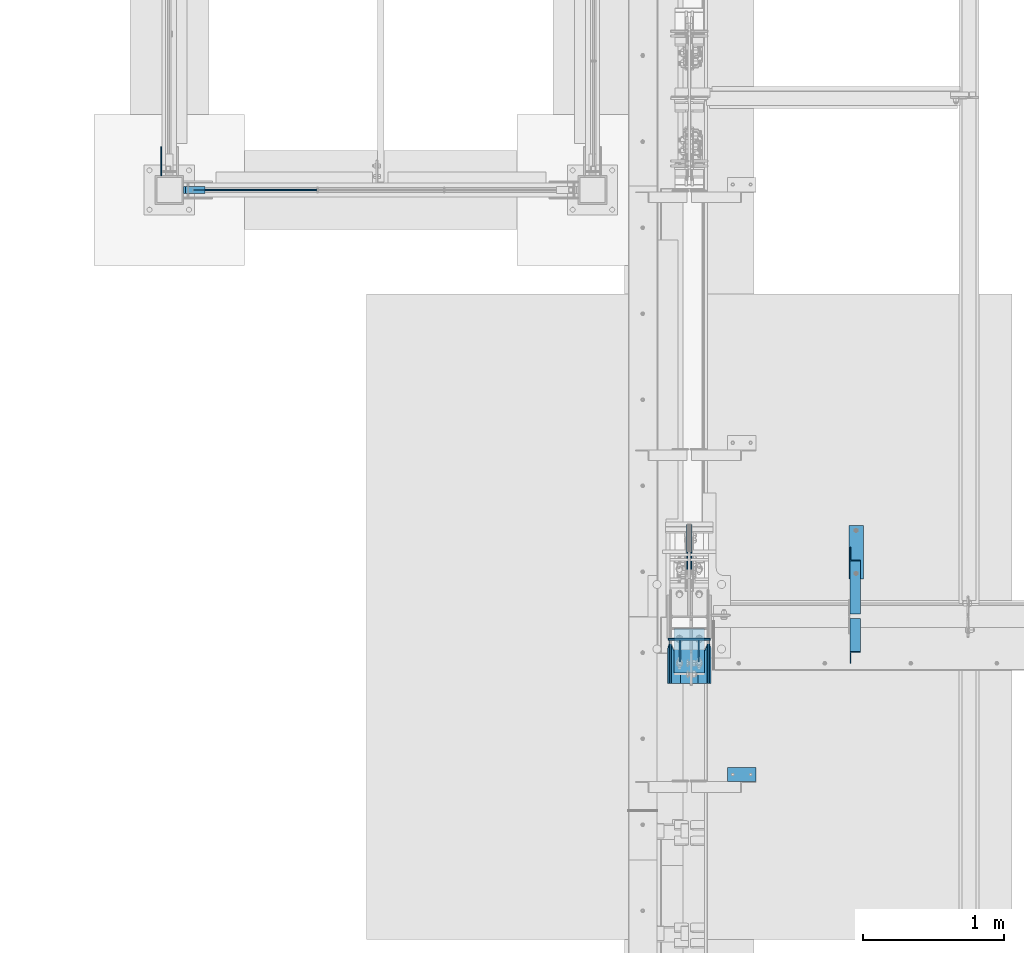
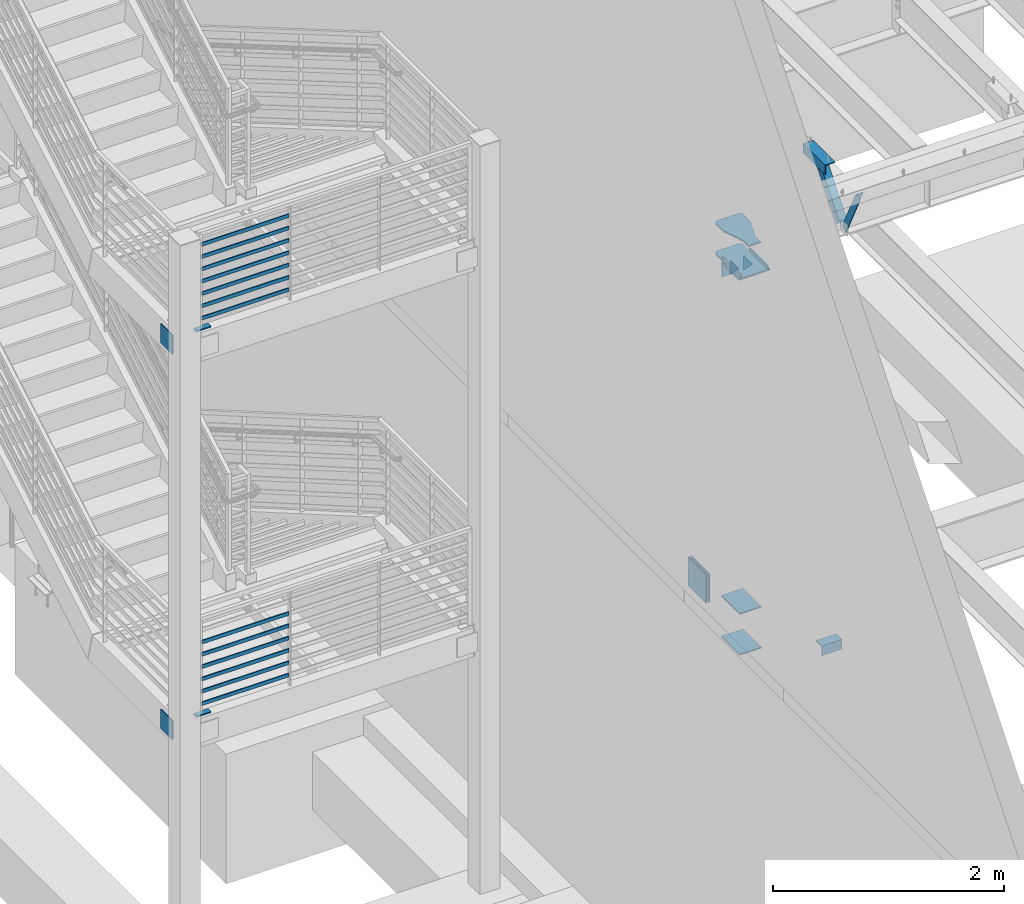
# One storey, part 830 of 1179: 30 beams, 2 members, 13 elements without a shape of their own.
"""IFC2X3 building model written with IfcOpenShell, lengths in millimetres."""

import ifcopenshell
import ifcopenshell.guid

model = None  # the IFC model being written
_history = None  # IfcOwnerHistory: only IFC2X3 demands one
_inside = {}  # id of a spatial element -> (the spatial element, [elements in it])
_under = {}  # id of a project, library or spatial element -> (it, [spatial elements below it])
_declared = {}  # id of a project -> (the project, [libraries it declares])
_typed = {}  # id of a type object -> (the type object, [elements of that type])
_made_of = {}  # id of a material, layer set ... -> (it, [elements and type objects made of it])


def new_model(schema):
    """Start an empty IFC model of exactly this schema.

    Asked for "IFC4X3", IfcOpenShell would pick the latest addendum, in which some entities
    have other attributes; the version numbers below select the first issue.
    IFC2X3 requires an IfcOwnerHistory on every rooted entity: one is made here for all.
    """
    global model, _history
    if schema == "IFC4X3":
        model = ifcopenshell.file(schema_version=(4, 3, 0, 0))
    else:
        model = ifcopenshell.file(schema=schema)
    _inside.clear()
    _under.clear()
    _declared.clear()
    _typed.clear()
    _made_of.clear()
    _history = None
    if model.schema == "IFC2X3":
        org = make("IfcOrganization", Name="unknown")
        user = make(
            "IfcPersonAndOrganization",
            ThePerson=make("IfcPerson", FamilyName="unknown"),
            TheOrganization=org,
        )
        app = make(
            "IfcApplication",
            ApplicationDeveloper=org,
            Version="unknown",
            ApplicationFullName="unknown",
            ApplicationIdentifier="unknown",
        )
        _history = make(
            "IfcOwnerHistory",
            OwningUser=user,
            OwningApplication=app,
            ChangeAction="ADDED",
            CreationDate=0,
        )
    return model


def make(cls, **values):
    """One entity of the class cls with the attributes given. An attribute that is None is left unset."""
    return model.create_entity(
        cls, **{name: value for name, value in values.items() if value is not None}
    )


def rooted(cls, **values):
    """An entity with a GlobalId (a new one), such as an element, a storey or a relation."""
    return make(cls, GlobalId=ifcopenshell.guid.new(), OwnerHistory=_history, **values)


def si_unit(unit_type, name, prefix=None):
    """IfcSIUnit, for example si_unit("LENGTHUNIT", "METRE", prefix="MILLI")."""
    return make("IfcSIUnit", UnitType=unit_type, Prefix=prefix, Name=name)


def assignment(units):
    """IfcUnitAssignment: the units of a project."""
    return None if units is None else make("IfcUnitAssignment", Units=units)


def point(xyz):
    """IfcCartesianPoint."""
    return None if xyz is None else make("IfcCartesianPoint", Coordinates=xyz)


def direction(xyz):
    """IfcDirection."""
    return None if xyz is None else make("IfcDirection", DirectionRatios=xyz)


def frame(location, z_axis=None, x_axis=None):
    """IfcAxis2Placement3D, a coordinate frame: its origin and axes. An axis left out is left unset."""
    return make(
        "IfcAxis2Placement3D",
        Location=point(location),
        Axis=direction(z_axis),
        RefDirection=direction(x_axis),
    )


def origin_with_axes():
    """The frame at (0, 0, 0) with the z axis (0, 0, 1) and the x axis (1, 0, 0) written out."""
    return frame((0.0, 0.0, 0.0), z_axis=(0.0, 0.0, 1.0), x_axis=(1.0, 0.0, 0.0))


def place(relative_to, where):
    """IfcLocalPlacement: puts the frame where relative to a parent placement (None: the world)."""
    return make(
        "IfcLocalPlacement", PlacementRelTo=relative_to, RelativePlacement=where
    )


def context(
    kind, dimensions, precision=None, world=None, true_north=None, identifier=None
):
    """IfcGeometricRepresentationContext, for example the 3D "Model" context."""
    return make(
        "IfcGeometricRepresentationContext",
        ContextIdentifier=identifier,
        ContextType=kind,
        CoordinateSpaceDimension=dimensions,
        Precision=precision,
        WorldCoordinateSystem=world,
        TrueNorth=true_north,
    )


def subcontext(parent, identifier, kind, view, scale=None):
    """IfcGeometricRepresentationSubContext, for example "Body" below "Model"."""
    return make(
        "IfcGeometricRepresentationSubContext",
        ContextIdentifier=identifier,
        ContextType=kind,
        ParentContext=parent,
        TargetScale=scale,
        TargetView=view,
    )


def project(units=None, contexts=None):
    """IfcProject with its units and contexts."""
    return rooted(
        "IfcProject",
        Name="project",
        RepresentationContexts=contexts,
        UnitsInContext=assignment(units),
    )


def spatial(cls, under=None, at=None, **own):
    """A site, building, storey or space (cls), placed at a placement, below another one or the project."""
    s = rooted(cls, ObjectPlacement=at, **own)
    if under is not None:
        _under.setdefault(under.id(), (under, []))[1].append(s)
    return s


def faces_of(points, faces, orient=None, outer=None):
    """IfcFace entities. A face is a list of loops; a loop is a list of indices into points, from 0.

    orient and outer hold one flag for each loop. By default every Orientation is true, the
    first loop of a face is its IfcFaceOuterBound and the others are IfcFaceBound.
    """
    made = []
    for i, loops in enumerate(faces):
        bounds = []
        for j, loop in enumerate(loops):
            is_outer = j == 0 if outer is None else outer[i][j]
            bounds.append(
                make(
                    "IfcFaceOuterBound" if is_outer else "IfcFaceBound",
                    Bound=make("IfcPolyLoop", Polygon=[points[k] for k in loop]),
                    Orientation=True if orient is None else orient[i][j],
                )
            )
        made.append(make("IfcFace", Bounds=bounds))
    return made


def faceted_brep(points, faces, orient=None, outer=None, voids=None):
    """IfcFacetedBrep: a solid bounded by flat faces; with voids (closed shells), ...WithVoids."""
    shared = [point(p) for p in points]
    hull = make("IfcClosedShell", CfsFaces=faces_of(shared, faces, orient, outer))
    if voids is None:
        return make("IfcFacetedBrep", Outer=hull)
    return make(
        "IfcFacetedBrepWithVoids",
        Outer=hull,
        Voids=[
            make(cls, CfsFaces=faces_of(shared, fs, o, b)) for cls, fs, o, b in voids
        ],
    )


def shape(context_of_items, identifier, shape_type, items):
    """IfcShapeRepresentation: the items that make up one representation, for example the "Body"."""
    return make(
        "IfcShapeRepresentation",
        ContextOfItems=context_of_items,
        RepresentationIdentifier=identifier,
        RepresentationType=shape_type,
        Items=items,
    )


def material(Name=None, Category=None):
    """IfcMaterial."""
    return make("IfcMaterial", Name=Name, Category=Category)


def made_of(thing, what):
    """Note that an element or type object is made of a material, layer set ...; save() writes the relation."""
    if what is not None:
        _made_of.setdefault(what.id(), (what, []))[1].append(thing)
    return thing


def type_object(cls, material=None, **own):
    """A type object (cls), such as IfcWallType, which elements share."""
    return made_of(rooted(cls, **own), material)


def element(
    cls,
    number,
    at=None,
    inside=None,
    cuts=None,
    type_object=None,
    material=None,
    context=None,
    identifier="Body",
    shape_type=None,
    held_by="IfcProductDefinitionShape",
    body=None,
    shapes=None,
    **own,
):
    """One element of the class cls, such as IfcWall. Its Tag is "e" and its number.

    at: its placement. inside: the storey or other place that contains it. cuts: it is an
    opening in that element (IfcRelVoidsElement). A single representation is given by context,
    identifier, shape_type and body (its items); several are given by shapes. held_by: the class
    of the entity that holds the representations. save() writes the other relations.
    """
    e = rooted(cls, Tag="e%d" % number, ObjectPlacement=at, **own)
    if body is not None:
        shapes = [shape(context, identifier, shape_type, body)]
    if shapes is not None:
        e.Representation = make(held_by, Representations=shapes)
    if inside is not None:
        _inside.setdefault(inside.id(), (inside, []))[1].append(e)
    if cuts is not None:
        rooted(
            "IfcRelVoidsElement", RelatingBuildingElement=cuts, RelatedOpeningElement=e
        )
    if type_object is not None:
        _typed.setdefault(type_object.id(), (type_object, []))[1].append(e)
    return made_of(e, material)


def aggregate(whole, parts):
    """IfcRelAggregates: a whole, such as a stair, and the parts it consists of."""
    return rooted("IfcRelAggregates", RelatingObject=whole, RelatedObjects=parts)


def save(model, path):
    """Write the relations noted so far, then the file.

    IfcRelAggregates (storeys below a building ...), IfcRelContainedInSpatialStructure (elements
    in a storey), IfcRelDefinesByType, IfcRelAssociatesMaterial and IfcRelDeclares: one each for
    every whole, place, type object, material and project.
    """
    for whole, parts in _under.values():
        aggregate(whole, parts)
    for where, things in _inside.values():
        rooted(
            "IfcRelContainedInSpatialStructure",
            RelatedElements=things,
            RelatingStructure=where,
        )
    for kind, things in _typed.values():
        rooted("IfcRelDefinesByType", RelatedObjects=things, RelatingType=kind)
    for what, things in _made_of.values():
        rooted("IfcRelAssociatesMaterial", RelatedObjects=things, RelatingMaterial=what)
    for by, libraries in _declared.values():
        rooted("IfcRelDeclares", RelatingContext=by, RelatedDefinitions=libraries)
    model.write(path)


model = new_model("IFC2X3")

# Units and contexts
model_context = context("Model", 3, precision=1e-05, world=origin_with_axes())
body_context = subcontext(model_context, "Body", "Model", "MODEL_VIEW")
ifc_project = project(units=[si_unit("LENGTHUNIT", "METRE", prefix="MILLI"), si_unit("AREAUNIT", "SQUARE_METRE"), si_unit("VOLUMEUNIT", "CUBIC_METRE"), si_unit("MASSUNIT", "GRAM", prefix="KILO"), si_unit("TIMEUNIT", "SECOND"), si_unit("PLANEANGLEUNIT", "RADIAN"), si_unit("SOLIDANGLEUNIT", "STERADIAN"), si_unit("THERMODYNAMICTEMPERATUREUNIT", "DEGREE_CELSIUS"), si_unit("LUMINOUSINTENSITYUNIT", "LUMEN")], contexts=[model_context])

# Site, building, storey
site_placement = place(None, origin_with_axes())
site = spatial("IfcSite", under=ifc_project, at=site_placement, CompositionType="ELEMENT")
building_placement = place(site_placement, origin_with_axes())
building = spatial("IfcBuilding", under=site, at=building_placement, Name="Undefined", CompositionType="ELEMENT")
storey_placement = place(building_placement, origin_with_axes())
storey = spatial("IfcBuildingStorey", under=building, at=storey_placement, Name="Undefined", CompositionType="ELEMENT", Elevation=0.0)

# Assembly, beam
assembly_1_placement = place(storey_placement, origin_with_axes())
assembly_1 = element("IfcElementAssembly", 1, at=assembly_1_placement, inside=storey, Name="PLATE", AssemblyPlace="NOTDEFINED", PredefinedType="RIGID_FRAME")
ifc_material_1 = material(Name="STEEL/A572-GR.50")
beam_type_1 = type_object("IfcBeamType", PredefinedType="NOTDEFINED")
beam_1_placement = place(assembly_1_placement, frame((-2997.2, 30073.6, 2174.875), z_axis=(0.0, -1.0, 0.0), x_axis=(-1.0, 0.0, 0.0)))
beam_1 = element("IfcBeam", 2, at=beam_1_placement, type_object=beam_type_1, material=ifc_material_1, Name="PLATE", context=body_context, shape_type="Brep", body=[
    faceted_brep([(152.399999999998, 6.35000000000036, 25.4000000000015), (139.699999999998, -6.35000000000036, 25.4000000000015), (139.699999999998, -6.35000000000036, -25.4000000000015), (152.399999999998, 6.35000000000036, -25.4000000000015), (0.0, -6.35000000000036, -25.4000000000015), (0.0, -6.35000000000036, 25.4000000000015), (0.0, 6.35000000000036, 25.4000000000015), (0.0, 6.35000000000036, -25.4000000000015)], [[[0, 1, 2, 3]], [[4, 5, 6, 7]], [[7, 6, 0, 3]], [[4, 7, 3, 2]], [[5, 4, 2, 1]], [[6, 5, 1, 0]]]),
])
aggregate(assembly_1, [beam_1])

assembly_2_placement = place(storey_placement, origin_with_axes())
assembly_2 = element("IfcElementAssembly", 3, at=assembly_2_placement, inside=storey, Name="PLATE", AssemblyPlace="NOTDEFINED", PredefinedType="RIGID_FRAME")
beam_2_placement = place(assembly_2_placement, frame((-2997.2, 30073.6, 6248.4), z_axis=(0.0, -1.0, 0.0), x_axis=(-1.0, 0.0, 0.0)))
beam_2 = element("IfcBeam", 4, at=beam_2_placement, type_object=beam_type_1, material=ifc_material_1, Name="PLATE", context=body_context, shape_type="Brep", body=[
    faceted_brep([(152.399999999998, 6.35000000000036, 25.4000000000015), (139.699999999998, -6.35000000000036, 25.4000000000015), (139.699999999998, -6.35000000000036, -25.4000000000015), (152.399999999998, 6.35000000000036, -25.4000000000015), (0.0, -6.35000000000036, -25.4000000000015), (0.0, -6.35000000000036, 25.4000000000015), (0.0, 6.35000000000036, 25.4000000000015), (0.0, 6.35000000000036, -25.4000000000015)], [[[0, 1, 2, 3]], [[4, 5, 6, 7]], [[7, 6, 0, 3]], [[4, 7, 3, 2]], [[5, 4, 2, 1]], [[6, 5, 1, 0]]]),
])
aggregate(assembly_2, [beam_2])

# Assembly, beams
assembly_3_placement = place(storey_placement, origin_with_axes())
assembly_3 = element("IfcElementAssembly", 5, at=assembly_3_placement, inside=storey, Name="GUARDRAIL", AssemblyPlace="NOTDEFINED", PredefinedType="RIGID_FRAME")
ifc_material_2 = material(Name="STEEL/A36")
beam_type_2 = type_object("IfcBeamType", PredefinedType="NOTDEFINED")
beam_3_placement = place(assembly_3_placement, frame((-3098.8000000022, 30073.6, 6350.05291815882), z_axis=(0.0, 0.0, 1.0), x_axis=(1.0, 0.0, 0.0)))
beam_3 = element("IfcBeam", 6, at=beam_3_placement, type_object=beam_type_2, material=ifc_material_2, Name="PLATE", context=body_context, shape_type="Brep", body=[
    faceted_brep([(19.0499992371956, 4.76249999999709, -19.0499999999993), (19.0499992371956, 4.76249999999709, 19.0499999999993), (892.704166666667, 4.76249999999709, 19.0499999999993), (892.704166666667, 4.76249999999709, -19.0499999999993), (19.0499992371956, -4.76249999999709, 19.0499999999993), (892.704166666667, -4.76249999999709, 19.0499999999993), (19.0499992371956, -4.76249999999709, -19.0499999999993), (892.704166666667, -4.76249999999709, -19.0499999999993)], [[[0, 1, 2, 3]], [[1, 4, 5, 2]], [[4, 6, 7, 5]], [[6, 0, 3, 7]], [[5, 7, 3, 2]], [[6, 4, 1, 0]]]),
])
beam_4_placement = place(assembly_3_placement, frame((-3098.8000000022, 30073.6, 6480.22791861197), z_axis=(0.0, 0.0, 1.0), x_axis=(1.0, 0.0, 0.0)))
beam_4 = element("IfcBeam", 7, at=beam_4_placement, type_object=beam_type_2, material=ifc_material_2, Name="PLATE", context=body_context, shape_type="Brep", body=[
    faceted_brep([(19.0499992371956, 4.76249999999709, -19.0499999999993), (19.0499992371956, 4.76249999999709, 19.0499999999993), (892.704166666667, 4.76249999999709, 19.0499999999993), (892.704166666667, 4.76249999999709, -19.0499999999993), (19.0499992371956, -4.76249999999709, 19.0499999999993), (892.704166666667, -4.76249999999709, 19.0499999999993), (19.0499992371956, -4.76249999999709, -19.0499999999993), (892.704166666667, -4.76249999999709, -19.0499999999993)], [[[0, 1, 2, 3]], [[1, 4, 5, 2]], [[4, 6, 7, 5]], [[6, 0, 3, 7]], [[5, 7, 3, 2]], [[6, 4, 1, 0]]]),
])
beam_5_placement = place(assembly_3_placement, frame((-3098.8000000022, 30073.6, 6610.40291817129), z_axis=(0.0, 0.0, 1.0), x_axis=(1.0, 0.0, 0.0)))
beam_5 = element("IfcBeam", 8, at=beam_5_placement, type_object=beam_type_2, material=ifc_material_2, Name="PLATE", context=body_context, shape_type="Brep", body=[
    faceted_brep([(19.0499992371956, 4.76249999999709, -19.0499999999993), (19.0499992371956, 4.76249999999709, 19.0499999999993), (892.704166666667, 4.76249999999709, 19.0499999999993), (892.704166666667, 4.76249999999709, -19.0499999999993), (19.0499992371956, -4.76249999999709, 19.0499999999993), (892.704166666667, -4.76249999999709, 19.0499999999993), (19.0499992371956, -4.76249999999709, -19.0499999999993), (892.704166666667, -4.76249999999709, -19.0499999999993)], [[[0, 1, 2, 3]], [[1, 4, 5, 2]], [[4, 6, 7, 5]], [[6, 0, 3, 7]], [[5, 7, 3, 2]], [[6, 4, 1, 0]]]),
])
beam_6_placement = place(assembly_3_placement, frame((-3098.8000000022, 30073.6, 6740.57791918443), z_axis=(0.0, 0.0, 1.0), x_axis=(1.0, 0.0, 0.0)))
beam_6 = element("IfcBeam", 9, at=beam_6_placement, type_object=beam_type_2, material=ifc_material_2, Name="PLATE", context=body_context, shape_type="Brep", body=[
    faceted_brep([(19.0499992371956, 4.76249999999709, -19.0499999999993), (19.0499992371956, 4.76249999999709, 19.0499999999993), (892.704166666667, 4.76249999999709, 19.0499999999993), (892.704166666667, 4.76249999999709, -19.0499999999993), (19.0499992371956, -4.76249999999709, 19.0499999999993), (892.704166666667, -4.76249999999709, 19.0499999999993), (19.0499992371956, -4.76249999999709, -19.0499999999993), (892.704166666667, -4.76249999999709, -19.0499999999993)], [[[0, 1, 2, 3]], [[1, 4, 5, 2]], [[4, 6, 7, 5]], [[6, 0, 3, 7]], [[5, 7, 3, 2]], [[6, 4, 1, 0]]]),
])
beam_7_placement = place(assembly_3_placement, frame((-3098.8000000022, 30073.6, 6870.7529191827), z_axis=(0.0, 0.0, 1.0), x_axis=(1.0, 0.0, 0.0)))
beam_7 = element("IfcBeam", 10, at=beam_7_placement, type_object=beam_type_2, material=ifc_material_2, Name="PLATE", context=body_context, shape_type="Brep", body=[
    faceted_brep([(19.0499992371956, 4.76249999999709, -19.0499999999993), (19.0499992371956, 4.76249999999709, 19.0499999999993), (892.704166666667, 4.76249999999709, 19.0499999999993), (892.704166666667, 4.76249999999709, -19.0499999999993), (19.0499992371956, -4.76249999999709, 19.0499999999993), (892.704166666667, -4.76249999999709, 19.0499999999993), (19.0499992371956, -4.76249999999709, -19.0499999999993), (892.704166666667, -4.76249999999709, -19.0499999999993)], [[[0, 1, 2, 3]], [[1, 4, 5, 2]], [[4, 6, 7, 5]], [[6, 0, 3, 7]], [[5, 7, 3, 2]], [[6, 4, 1, 0]]]),
])
beam_8_placement = place(assembly_3_placement, frame((-3098.8000000022, 30073.6, 7000.92791918618), z_axis=(0.0, 0.0, 1.0), x_axis=(1.0, 0.0, 0.0)))
beam_8 = element("IfcBeam", 11, at=beam_8_placement, type_object=beam_type_2, material=ifc_material_2, Name="PLATE", context=body_context, shape_type="Brep", body=[
    faceted_brep([(19.0499992371956, 4.76249999999709, -19.0499999999993), (19.0499992371956, 4.76249999999709, 19.0499999999993), (892.704166666667, 4.76249999999709, 19.0499999999993), (892.704166666667, 4.76249999999709, -19.0499999999993), (19.0499992371956, -4.76249999999709, 19.0499999999993), (892.704166666667, -4.76249999999709, 19.0499999999993), (19.0499992371956, -4.76249999999709, -19.0499999999993), (892.704166666667, -4.76249999999709, -19.0499999999993)], [[[0, 1, 2, 3]], [[1, 4, 5, 2]], [[4, 6, 7, 5]], [[6, 0, 3, 7]], [[5, 7, 3, 2]], [[6, 4, 1, 0]]]),
])
beam_9_placement = place(assembly_3_placement, frame((-3098.8000000022, 30073.6, 7131.10291918618), z_axis=(0.0, 0.0, 1.0), x_axis=(1.0, 0.0, 0.0)))
beam_9 = element("IfcBeam", 12, at=beam_9_placement, type_object=beam_type_2, material=ifc_material_2, Name="PLATE", context=body_context, shape_type="Brep", body=[
    faceted_brep([(19.0499992371956, 4.76249999999709, -19.0499999999993), (19.0499992371956, 4.76249999999709, 19.0499999999993), (892.704166666667, 4.76249999999709, 19.0499999999993), (892.704166666667, 4.76249999999709, -19.0499999999993), (19.0499992371956, -4.76249999999709, 19.0499999999993), (892.704166666667, -4.76249999999709, 19.0499999999993), (19.0499992371956, -4.76249999999709, -19.0499999999993), (892.704166666667, -4.76249999999709, -19.0499999999993)], [[[0, 1, 2, 3]], [[1, 4, 5, 2]], [[4, 6, 7, 5]], [[6, 0, 3, 7]], [[5, 7, 3, 2]], [[6, 4, 1, 0]]]),
])
aggregate(assembly_3, [beam_3, beam_4, beam_5, beam_6, beam_7, beam_8, beam_9])

assembly_4_placement = place(storey_placement, origin_with_axes())
assembly_4 = element("IfcElementAssembly", 13, at=assembly_4_placement, inside=storey, Name="GUARDRAIL", AssemblyPlace="NOTDEFINED", PredefinedType="RIGID_FRAME")
beam_10_placement = place(assembly_4_placement, frame((-3098.8000000022, 30073.6, 2276.5279178486), z_axis=(0.0, 0.0, 1.0), x_axis=(1.0, 0.0, 0.0)))
beam_10 = element("IfcBeam", 14, at=beam_10_placement, type_object=beam_type_2, material=ifc_material_2, Name="PLATE", context=body_context, shape_type="Brep", body=[
    faceted_brep([(19.0499992371956, 4.76249999999709, -19.0499999999993), (19.0499992371956, 4.76249999999709, 19.0499999999993), (892.704166666667, 4.76249999999709, 19.0499999999993), (892.704166666667, 4.76249999999709, -19.0499999999993), (19.0499992371956, -4.76249999999709, 19.0499999999993), (892.704166666667, -4.76249999999709, 19.0499999999993), (19.0499992371956, -4.76249999999709, -19.0499999999993), (892.704166666667, -4.76249999999709, -19.0499999999993)], [[[0, 1, 2, 3]], [[1, 4, 5, 2]], [[4, 6, 7, 5]], [[6, 0, 3, 7]], [[5, 7, 3, 2]], [[6, 4, 1, 0]]]),
])
beam_11_placement = place(assembly_4_placement, frame((-3098.8000000022, 30073.6, 2406.70291830175), z_axis=(0.0, 0.0, 1.0), x_axis=(1.0, 0.0, 0.0)))
beam_11 = element("IfcBeam", 15, at=beam_11_placement, type_object=beam_type_2, material=ifc_material_2, Name="PLATE", context=body_context, shape_type="Brep", body=[
    faceted_brep([(19.0499992371956, 4.76249999999709, -19.0499999999993), (19.0499992371956, 4.76249999999709, 19.0499999999993), (892.704166666667, 4.76249999999709, 19.0499999999993), (892.704166666667, 4.76249999999709, -19.0499999999993), (19.0499992371956, -4.76249999999709, 19.0499999999993), (892.704166666667, -4.76249999999709, 19.0499999999993), (19.0499992371956, -4.76249999999709, -19.0499999999993), (892.704166666667, -4.76249999999709, -19.0499999999993)], [[[0, 1, 2, 3]], [[1, 4, 5, 2]], [[4, 6, 7, 5]], [[6, 0, 3, 7]], [[5, 7, 3, 2]], [[6, 4, 1, 0]]]),
])
beam_12_placement = place(assembly_4_placement, frame((-3098.8000000022, 30073.6, 2536.87791786107), z_axis=(0.0, 0.0, 1.0), x_axis=(1.0, 0.0, 0.0)))
beam_12 = element("IfcBeam", 16, at=beam_12_placement, type_object=beam_type_2, material=ifc_material_2, Name="PLATE", context=body_context, shape_type="Brep", body=[
    faceted_brep([(19.0499992371956, 4.76249999999709, -19.0499999999993), (19.0499992371956, 4.76249999999709, 19.0499999999993), (892.704166666667, 4.76249999999709, 19.0499999999993), (892.704166666667, 4.76249999999709, -19.0499999999993), (19.0499992371956, -4.76249999999709, 19.0499999999993), (892.704166666667, -4.76249999999709, 19.0499999999993), (19.0499992371956, -4.76249999999709, -19.0499999999993), (892.704166666667, -4.76249999999709, -19.0499999999993)], [[[0, 1, 2, 3]], [[1, 4, 5, 2]], [[4, 6, 7, 5]], [[6, 0, 3, 7]], [[5, 7, 3, 2]], [[6, 4, 1, 0]]]),
])
beam_13_placement = place(assembly_4_placement, frame((-3098.8000000022, 30073.6, 2667.05291887421), z_axis=(0.0, 0.0, 1.0), x_axis=(1.0, 0.0, 0.0)))
beam_13 = element("IfcBeam", 17, at=beam_13_placement, type_object=beam_type_2, material=ifc_material_2, Name="PLATE", context=body_context, shape_type="Brep", body=[
    faceted_brep([(19.0499992371956, 4.76249999999709, -19.0499999999993), (19.0499992371956, 4.76249999999709, 19.0499999999993), (892.704166666667, 4.76249999999709, 19.0499999999993), (892.704166666667, 4.76249999999709, -19.0499999999993), (19.0499992371956, -4.76249999999709, 19.0499999999993), (892.704166666667, -4.76249999999709, 19.0499999999993), (19.0499992371956, -4.76249999999709, -19.0499999999993), (892.704166666667, -4.76249999999709, -19.0499999999993)], [[[0, 1, 2, 3]], [[1, 4, 5, 2]], [[4, 6, 7, 5]], [[6, 0, 3, 7]], [[5, 7, 3, 2]], [[6, 4, 1, 0]]]),
])
beam_14_placement = place(assembly_4_placement, frame((-3098.8000000022, 30073.6, 2797.22791887248), z_axis=(0.0, 0.0, 1.0), x_axis=(1.0, 0.0, 0.0)))
beam_14 = element("IfcBeam", 18, at=beam_14_placement, type_object=beam_type_2, material=ifc_material_2, Name="PLATE", context=body_context, shape_type="Brep", body=[
    faceted_brep([(19.0499992371956, 4.76249999999709, -19.0499999999993), (19.0499992371956, 4.76249999999709, 19.0499999999993), (892.704166666667, 4.76249999999709, 19.0499999999993), (892.704166666667, 4.76249999999709, -19.0499999999993), (19.0499992371956, -4.76249999999709, 19.0499999999993), (892.704166666667, -4.76249999999709, 19.0499999999993), (19.0499992371956, -4.76249999999709, -19.0499999999993), (892.704166666667, -4.76249999999709, -19.0499999999993)], [[[0, 1, 2, 3]], [[1, 4, 5, 2]], [[4, 6, 7, 5]], [[6, 0, 3, 7]], [[5, 7, 3, 2]], [[6, 4, 1, 0]]]),
])
beam_15_placement = place(assembly_4_placement, frame((-3098.8000000022, 30073.6, 2927.40291887596), z_axis=(0.0, 0.0, 1.0), x_axis=(1.0, 0.0, 0.0)))
beam_15 = element("IfcBeam", 19, at=beam_15_placement, type_object=beam_type_2, material=ifc_material_2, Name="PLATE", context=body_context, shape_type="Brep", body=[
    faceted_brep([(19.0499992371956, 4.76249999999709, -19.0499999999993), (19.0499992371956, 4.76249999999709, 19.0499999999993), (892.704166666667, 4.76249999999709, 19.0499999999993), (892.704166666667, 4.76249999999709, -19.0499999999993), (19.0499992371956, -4.76249999999709, 19.0499999999993), (892.704166666667, -4.76249999999709, 19.0499999999993), (19.0499992371956, -4.76249999999709, -19.0499999999993), (892.704166666667, -4.76249999999709, -19.0499999999993)], [[[0, 1, 2, 3]], [[1, 4, 5, 2]], [[4, 6, 7, 5]], [[6, 0, 3, 7]], [[5, 7, 3, 2]], [[6, 4, 1, 0]]]),
])
aggregate(assembly_4, [beam_10, beam_11, beam_12, beam_13, beam_14, beam_15])

# Assembly, member
assembly_5_placement = place(storey_placement, origin_with_axes())
assembly_5 = element("IfcElementAssembly", 20, at=assembly_5_placement, inside=storey, Name="ANGLE", AssemblyPlace="NOTDEFINED", PredefinedType="RIGID_FRAME")
member_type = type_object("IfcMemberType", Name="L3X3X1/4", PredefinedType="NOTDEFINED")
member_1_placement = place(assembly_5_placement, frame((1608.1375, 27508.2, 8013.7), z_axis=(0.0, 0.7672237920886, -0.641379492074067), x_axis=(0.0, -0.641379492074066, -0.767223792088601)))
member_1 = element("IfcMember", 21, at=member_1_placement, type_object=member_type, material=ifc_material_2, Name="ANGLE", ObjectType="L3X3X1/4", context=body_context, shape_type="Brep", body=[
    faceted_brep([(52.5421123063024, 38.0999999999985, -38.0999999999967), (-11.159141226166, 38.0999999999985, 38.1000000000095), (634.651401994255, 38.0999999999985, 38.1000000003041), (634.651401994233, 38.0999999999985, -38.0999999997293), (-11.159141226166, 31.75, 38.1000000000095), (634.651401994255, 31.75, 38.1000000003041), (47.2336745119283, 31.75, -31.7499999999982), (634.651401994237, 31.75, -31.7499999997272), (47.2336745119283, -38.0999999999985, -31.7499999999982), (634.651401994237, -38.0999999999985, -31.7499999997272), (52.5421123063024, -38.0999999999985, -38.0999999999967), (634.651401994233, -38.0999999999985, -38.0999999997293)], [[[0, 1, 2, 3]], [[1, 4, 5, 2]], [[4, 6, 7, 5]], [[6, 8, 9, 7]], [[8, 10, 11, 9]], [[10, 0, 3, 11]], [[5, 7, 9, 11, 3, 2]], [[10, 8, 6, 4, 1, 0]]]),
])
aggregate(assembly_5, [member_1])

assembly_6_placement = place(storey_placement, origin_with_axes())
assembly_6 = element("IfcElementAssembly", 22, at=assembly_6_placement, inside=storey, Name="ANGLE", AssemblyPlace="NOTDEFINED", PredefinedType="RIGID_FRAME")
member_2_placement = place(assembly_6_placement, frame((1608.1375, 27005.4961357473, 7519.97080646429), z_axis=(0.0, -0.897509848200057, -0.440994413098296), x_axis=(0.0, -0.440994413098296, 0.897509848200057)))
member_2 = element("IfcMember", 23, at=member_2_placement, type_object=member_type, material=ifc_material_2, Name="ANGLE", ObjectType="L3X3X1/4", context=body_context, shape_type="Brep", body=[
    faceted_brep([(0.0, 38.0999999999985, -38.0999999999999), (0.0, 38.0999999999985, 38.0999999999999), (568.830616953598, 38.0999999999985, 38.0999999992709), (531.389496563324, 38.0999999999985, -38.1000000007189), (0.0, 31.75, 38.1000000000004), (568.830616953598, 31.75, 38.0999999992709), (0.0, 31.75, -31.75), (534.509589929181, 31.75, -31.7500000007203), (0.0, -38.0999999999985, -31.75), (534.509589929181, -38.0999999999985, -31.7500000007203), (0.0, -38.0999999999985, -38.0999999999999), (531.389496563324, -38.0999999999985, -38.1000000007189)], [[[0, 1, 2, 3]], [[1, 4, 5, 2]], [[4, 6, 7, 5]], [[6, 8, 9, 7]], [[8, 10, 11, 9]], [[10, 0, 3, 11]], [[5, 7, 9, 11, 3, 2]], [[10, 8, 6, 4, 1, 0]]]),
])
aggregate(assembly_6, [member_2])

# Assembly, beams
assembly_7_placement = place(storey_placement, origin_with_axes())
assembly_7 = element("IfcElementAssembly", 24, at=assembly_7_placement, inside=storey, Name="COLUMN", AssemblyPlace="NOTDEFINED", PredefinedType="RIGID_FRAME")
beam_type_3 = type_object("IfcBeamType", PredefinedType="NOTDEFINED")
beam_16_placement = place(assembly_7_placement, frame((284.162500000006, 26890.6625, 7616.82500000912), z_axis=(0.0, 0.0, 1.0), x_axis=(1.0, 0.0, 0.0)))
beam_16 = element("IfcBeam", 25, at=beam_16_placement, type_object=beam_type_3, material=ifc_material_2, Name="PLATE", context=body_context, shape_type="Brep", body=[
    faceted_brep([(-7.27595761418343e-12, 6.35000000000036, -76.1999999999971), (0.0, 6.35000000000036, 76.2000000000044), (295.274999999994, 6.34999999999854, 76.2000000000007), (295.274999999994, 6.34999999999854, -76.2000000000007), (0.0, -6.35000000000036, 76.2000000000044), (295.274999999994, -6.34999999999854, 76.2000000000007), (7.27595761418343e-12, -6.35000000000036, -76.1999999999971), (295.274999999994, -6.34999999999854, -76.2000000000007)], [[[0, 1, 2, 3]], [[1, 4, 5, 2]], [[4, 6, 7, 5]], [[6, 0, 3, 7]], [[5, 7, 3, 2]], [[6, 4, 1, 0]]]),
])
beam_type_4 = type_object("IfcBeamType", PredefinedType="NOTDEFINED")
beam_17_placement = place(assembly_7_placement, frame((431.800000000004, 26968.45, 3676.65), z_axis=(-1.0, 0.0, 0.0), x_axis=(0.0, -1.0, 0.0)))
beam_17 = element("IfcBeam", 26, at=beam_17_placement, type_object=beam_type_4, material=ifc_material_1, Name="PLATE", context=body_context, shape_type="Brep", body=[
    faceted_brep([(0.0, 6.35000000000036, -107.949999999997), (0.0, 6.35000000000036, 107.949999999997), (317.5, 6.35000000000036, 107.949999999997), (317.5, 6.35000000000036, -107.949999999997), (0.0, -6.35000000000036, 107.949999999997), (317.5, -6.35000000000036, 107.949999999997), (0.0, -6.35000000000036, -107.949999999997), (317.5, -6.35000000000036, -107.949999999997)], [[[0, 1, 2, 3]], [[1, 4, 5, 2]], [[4, 6, 7, 5]], [[6, 0, 3, 7]], [[5, 7, 3, 2]], [[6, 4, 1, 0]]]),
])
beam_18_placement = place(assembly_7_placement, frame((431.800000000004, 26968.45, 4108.45), z_axis=(-1.0, 0.0, 0.0), x_axis=(0.0, -1.0, 0.0)))
beam_18 = element("IfcBeam", 27, at=beam_18_placement, type_object=beam_type_4, material=ifc_material_1, Name="PLATE", context=body_context, shape_type="Brep", body=[
    faceted_brep([(0.0, 6.35000000000036, -107.949999999997), (0.0, 6.35000000000036, 107.949999999997), (317.5, 6.35000000000036, 107.949999999997), (317.5, 6.35000000000036, -107.949999999997), (0.0, -6.35000000000036, 107.949999999997), (317.5, -6.35000000000036, 107.949999999997), (0.0, -6.35000000000036, -107.949999999997), (317.5, -6.35000000000036, -107.949999999997)], [[[0, 1, 2, 3]], [[1, 4, 5, 2]], [[4, 6, 7, 5]], [[6, 0, 3, 7]], [[5, 7, 3, 2]], [[6, 4, 1, 0]]]),
])

# Assembly, beam
assembly_8_placement = place(storey_placement, origin_with_axes())
assembly_8 = element("IfcElementAssembly", 28, at=assembly_8_placement, inside=storey, Name="ANGLE", AssemblyPlace="NOTDEFINED", PredefinedType="RIGID_FRAME")
beam_type_5 = type_object("IfcBeamType", Name="L4X4X1/4", PredefinedType="NOTDEFINED")
beam_19_placement = place(assembly_8_placement, frame((1614.4875, 27317.6213553416, 7962.9), z_axis=(1.0, 0.0, 0.0), x_axis=(0.0, 1.0, 0.0)))
beam_19 = element("IfcBeam", 29, at=beam_19_placement, type_object=beam_type_5, material=ifc_material_2, Name="ANGLE", ObjectType="L4X4X1/4", context=body_context, shape_type="Brep", body=[
    faceted_brep([(1.90993887372315e-11, 50.8000000000002, -50.8000000000002), (1.90993887372315e-11, 50.8000000000002, 50.8000000000002), (381.0, 50.8000000000002, 50.7999999999993), (381.0, 50.8000000000002, -50.7999999999993), (0.0, 44.4500000000007, 50.8000000000002), (381.0, 44.4499999999998, 50.7999999999993), (0.0, 44.4500000000007, -44.4499999999998), (381.0, 44.4499999999998, -44.4500000000007), (0.0, -50.7999999999993, -44.4499999999998), (381.0, -50.8000000000002, -44.4500000000007), (-1.81898940354586e-11, -50.7999999999997, -50.8000000000002), (381.0, -50.8000000000002, -50.7999999999993)], [[[0, 1, 2, 3]], [[1, 4, 5, 2]], [[4, 6, 7, 5]], [[6, 8, 9, 7]], [[8, 10, 11, 9]], [[10, 0, 3, 11]], [[5, 7, 9, 11, 3, 2]], [[10, 8, 6, 4, 1, 0]]]),
])
aggregate(assembly_8, [beam_19])

assembly_9_placement = place(storey_placement, origin_with_axes())
assembly_9 = element("IfcElementAssembly", 30, at=assembly_9_placement, inside=storey, Name="ANGLE", AssemblyPlace="NOTDEFINED", PredefinedType="RIGID_FRAME")
beam_20_placement = place(assembly_9_placement, frame((701.59635534156, 25933.4, 4051.3), z_axis=(0.0, 0.0, -1.0), x_axis=(1.0, 0.0, 0.0)))
beam_20 = element("IfcBeam", 31, at=beam_20_placement, type_object=beam_type_5, material=ifc_material_2, Name="ANGLE", ObjectType="L4X4X1/4", context=body_context, shape_type="Brep", body=[
    faceted_brep([(1.90993887372315e-11, 50.8000000000002, -50.8000000000002), (1.90993887372315e-11, 50.8000000000002, 50.8000000000002), (203.200000000001, 50.7999999999993, 50.8000000000002), (203.200000000001, 50.7999999999993, -50.8000000000002), (0.0, 44.4500000000007, 50.8000000000002), (203.200000000001, 44.4500000000007, 50.8000000000002), (0.0, 44.4500000000007, -44.4499999999998), (203.200000000001, 44.4500000000007, -44.4499999999998), (0.0, -50.7999999999993, -44.4499999999998), (203.200000000001, -50.7999999999993, -44.4499999999998), (-1.81898940354586e-11, -50.7999999999997, -50.8000000000002), (203.200000000001, -50.7999999999993, -50.8000000000002)], [[[0, 1, 2, 3]], [[1, 4, 5, 2]], [[4, 6, 7, 5]], [[6, 8, 9, 7]], [[8, 10, 11, 9]], [[10, 0, 3, 11]], [[5, 7, 9, 11, 3, 2]], [[10, 8, 6, 4, 1, 0]]]),
])
aggregate(assembly_9, [beam_20])

# Assembly, beams
assembly_10_placement = place(storey_placement, origin_with_axes())
assembly_10 = element("IfcElementAssembly", 32, at=assembly_10_placement, inside=storey, Name="COLUMN", AssemblyPlace="NOTDEFINED", PredefinedType="RIGID_FRAME")
beam_type_6 = type_object("IfcBeamType", PredefinedType="NOTDEFINED")
beam_21_placement = place(assembly_10_placement, frame((-3308.35000001418, 30378.3999990897, 2016.07208180267), z_axis=(0.0, 0.0, 1.0), x_axis=(0.0, -1.0, 0.0)))
beam_21 = element("IfcBeam", 33, at=beam_21_placement, type_object=beam_type_6, material=ifc_material_2, Name="PLATE", context=body_context, shape_type="Brep", body=[
    faceted_brep([(0.0, 4.76250000000073, -101.6), (0.0, 4.76250000000073, 101.6), (203.199999999997, 4.76250000000073, 101.6), (203.199999999997, 4.76250000000073, -101.6), (0.0, -4.76250000000073, 101.6), (203.199999999997, -4.76250000000073, 101.6), (0.0, -4.76250000000073, -101.6), (203.199999999997, -4.76250000000073, -101.6)], [[[0, 1, 2, 3]], [[1, 4, 5, 2]], [[4, 6, 7, 5]], [[6, 0, 3, 7]], [[5, 7, 3, 2]], [[6, 4, 1, 0]]]),
])
beam_22_placement = place(assembly_10_placement, frame((-3308.35, 30378.4, 6089.65), z_axis=(0.0, 0.0, 1.0), x_axis=(0.0, -1.0, 0.0)))
beam_22 = element("IfcBeam", 34, at=beam_22_placement, type_object=beam_type_6, material=ifc_material_2, Name="PLATE", context=body_context, shape_type="Brep", body=[
    faceted_brep([(0.0, 4.76250000000073, -101.6), (0.0, 4.76250000000073, 101.6), (203.199999999997, 4.76250000000073, 101.6), (203.199999999997, 4.76250000000073, -101.6), (0.0, -4.76250000000073, 101.6), (203.199999999997, -4.76250000000073, 101.6), (0.0, -4.76250000000073, -101.6), (203.199999999997, -4.76250000000073, -101.6)], [[[0, 1, 2, 3]], [[1, 4, 5, 2]], [[4, 6, 7, 5]], [[6, 0, 3, 7]], [[5, 7, 3, 2]], [[6, 4, 1, 0]]]),
])
aggregate(assembly_10, [beam_21, beam_22])

# Assembly, beam
assembly_11_placement = place(storey_placement, origin_with_axes())
assembly_11 = element("IfcElementAssembly", 35, at=assembly_11_placement, inside=storey, Name="PLATE", AssemblyPlace="NOTDEFINED", PredefinedType="RIGID_FRAME")
beam_type_7 = type_object("IfcBeamType", PredefinedType="NOTDEFINED")
beam_23_placement = place(assembly_11_placement, frame((417.512500000002, 27703.683001131, 3892.55), z_axis=(0.0, 0.0, -1.0), x_axis=(0.0, -1.0, 0.0)))
beam_23 = element("IfcBeam", 36, at=beam_23_placement, type_object=beam_type_7, material=ifc_material_1, Name="PLATE", context=body_context, shape_type="Brep", body=[
    faceted_brep([(0.0, 4.76250000000073, -152.4), (0.0, 4.76250000000073, 152.4), (317.5, 4.76250000000073, 152.4), (317.5, 4.76250000000073, -152.4), (0.0, -4.76250000000073, 152.4), (317.5, -4.76250000000073, 152.4), (0.0, -4.76250000000073, -152.4), (317.5, -4.76250000000073, -152.4)], [[[0, 1, 2, 3]], [[1, 4, 5, 2]], [[4, 6, 7, 5]], [[6, 0, 3, 7]], [[5, 7, 3, 2]], [[6, 4, 1, 0]]]),
])
aggregate(assembly_11, [beam_23])

assembly_12_placement = place(storey_placement, origin_with_axes())
assembly_12 = element("IfcElementAssembly", 37, at=assembly_12_placement, inside=storey, Name="PLATE", AssemblyPlace="NOTDEFINED", PredefinedType="RIGID_FRAME")
beam_24_placement = place(assembly_12_placement, frame((446.087213611823, 27386.183001131, 3892.55), z_axis=(0.0, 0.0, -1.0), x_axis=(0.0, 1.0, 0.0)))
beam_24 = element("IfcBeam", 38, at=beam_24_placement, type_object=beam_type_7, material=ifc_material_1, Name="PLATE", context=body_context, shape_type="Brep", body=[
    faceted_brep([(0.0, 4.76250000000073, -152.4), (0.0, 4.76250000000073, 152.4), (317.5, 4.76250000000073, 152.4), (317.5, 4.76250000000073, -152.4), (0.0, -4.76250000000073, 152.4), (317.5, -4.76250000000073, 152.4), (0.0, -4.76250000000073, -152.4), (317.5, -4.76250000000073, -152.4)], [[[0, 1, 2, 3]], [[1, 4, 5, 2]], [[4, 6, 7, 5]], [[6, 0, 3, 7]], [[5, 7, 3, 2]], [[6, 4, 1, 0]]]),
])
aggregate(assembly_12, [beam_24])

# Beam
beam_type_8 = type_object("IfcBeamType", PredefinedType="NOTDEFINED")
beam_25_placement = place(assembly_7_placement, frame((296.862500000005, 26579.5125, 7727.95000000912), z_axis=(0.0, 0.0, 1.0), x_axis=(0.0, 1.0, 0.0)))
beam_25 = element("IfcBeam", 39, at=beam_25_placement, type_object=beam_type_8, material=ifc_material_2, Name="PLATE", context=body_context, shape_type="Brep", body=[
    faceted_brep([(0.0, 6.34999999999854, -19.0499999999993), (0.0, 6.35000000000036, 19.0499999999993), (317.5, 6.34999999999854, 19.0499999999993), (317.5, 6.34999999999854, -19.0499999999993), (0.0, -6.35000000000036, 19.0499999999993), (317.5, -6.34999999999854, 19.0499999999993), (0.0, -6.34999999999854, -19.0499999999993), (317.5, -6.34999999999854, -19.0499999999993)], [[[0, 1, 2, 3]], [[1, 4, 5, 2]], [[4, 6, 7, 5]], [[6, 0, 3, 7]], [[5, 7, 3, 2]], [[6, 4, 1, 0]]]),
])

beam_26_placement = place(assembly_7_placement, frame((566.737500000005, 26579.5125, 7727.95000000912), z_axis=(0.0, 0.0, 1.0), x_axis=(0.0, 1.0, 0.0)))
beam_26 = element("IfcBeam", 40, at=beam_26_placement, type_object=beam_type_8, material=ifc_material_2, Name="PLATE", context=body_context, shape_type="Brep", body=[
    faceted_brep([(0.0, 6.34999999999854, -19.0499999999993), (0.0, 6.35000000000036, 19.0499999999993), (317.5, 6.34999999999854, 19.0499999999993), (317.5, 6.34999999999854, -19.0499999999993), (0.0, -6.35000000000036, 19.0499999999993), (317.5, -6.34999999999854, 19.0499999999993), (0.0, -6.34999999999854, -19.0499999999993), (317.5, -6.34999999999854, -19.0499999999993)], [[[0, 1, 2, 3]], [[1, 4, 5, 2]], [[4, 6, 7, 5]], [[6, 0, 3, 7]], [[5, 7, 3, 2]], [[6, 4, 1, 0]]]),
])

beam_type_9 = type_object("IfcBeamType", PredefinedType="NOTDEFINED")
beam_27_placement = place(assembly_7_placement, frame((365.125000000004, 26731.9125, 7616.82500000912), z_axis=(0.0, 0.0, 1.0), x_axis=(0.0, 1.0, 0.0)))
beam_27 = element("IfcBeam", 41, at=beam_27_placement, type_object=beam_type_9, material=ifc_material_2, Name="PLATE", context=body_context, shape_type="Brep", body=[
    faceted_brep([(152.4, -4.76249999999709, 76.2), (152.4, -4.76249999999709, -76.2), (152.4, 4.76249999999709, -76.2), (152.4, 4.76249999999709, 76.2), (0.0, 4.76249999999982, 76.1999999999971), (0.0, -4.76249999999982, 76.1999999999971)], [[[0, 1, 2, 3]], [[3, 2, 4]], [[4, 5, 0, 3]], [[0, 5, 1]], [[4, 2, 1, 5]]]),
])

beam_28_placement = place(assembly_7_placement, frame((498.475000000002, 26731.9125, 7616.82500000912), z_axis=(0.0, 0.0, 1.0), x_axis=(0.0, 1.0, 0.0)))
beam_28 = element("IfcBeam", 42, at=beam_28_placement, type_object=beam_type_9, material=ifc_material_2, Name="PLATE", context=body_context, shape_type="Brep", body=[
    faceted_brep([(152.4, -4.76249999999709, 76.2), (152.4, -4.76249999999709, -76.2), (152.4, 4.76249999999709, -76.2), (152.4, 4.76249999999709, 76.2), (0.0, 4.76249999999982, 76.1999999999971), (0.0, -4.76249999999982, 76.1999999999971)], [[[0, 1, 2, 3]], [[3, 2, 4]], [[4, 5, 0, 3]], [[0, 5, 1]], [[4, 2, 1, 5]]]),
])

beam_type_10 = type_object("IfcBeamType", PredefinedType="NOTDEFINED")
beam_29_placement = place(assembly_7_placement, frame((431.800000000003, 26579.5125, 7700.96250000912), z_axis=(1.0, 0.0, 0.0), x_axis=(0.0, 1.0, 0.0)))
beam_29 = element("IfcBeam", 43, at=beam_29_placement, type_object=beam_type_10, material=ifc_material_2, Name="PLATE", context=body_context, shape_type="Brep", body=[
    faceted_brep([(465.137499999997, -7.9375, -114.300000762945), (442.912499999999, -7.9375, -136.525000762944), (442.912500000006, 7.9375, -136.525000762944), (465.137500000004, 7.9375, -114.300000762945), (465.137500000004, 7.9375, 114.300000762938), (442.912500000006, 7.9375, 136.525000762937), (442.912499999999, -7.9375, 136.525000762937), (465.137499999997, -7.9375, 114.300000762938), (241.300006103491, -7.9375, -155.575000000001), (241.300006103491, 7.9375, -155.575000000001), (304.799990844724, 7.9375, -136.525000762944), (304.799990844724, -7.9375, -136.525000762944), (0.0, -7.9375, -155.575000000001), (0.0, -7.9375, 155.575000000001), (0.0, 7.9375, 155.575000000001), (0.0, 7.9375, -155.575000000001), (241.300006103513, -7.9375, 155.575000000001), (241.300006103513, 7.9375, 155.575000000001), (304.799990844724, -7.9375, 136.525000762937), (304.799990844724, 7.9375, 136.525000762937)], [[[0, 1, 2, 3]], [[4, 5, 6, 7]], [[8, 9, 10, 11]], [[11, 10, 2, 1]], [[12, 13, 14, 15]], [[14, 13, 16, 17]], [[18, 19, 17, 16]], [[19, 18, 6, 5]], [[4, 7, 0, 3]], [[10, 9, 15, 14, 17, 19, 5, 4, 3, 2]], [[12, 15, 9, 8]], [[7, 6, 18, 16, 13, 12, 8, 11, 1, 0]]]),
])

aggregate(assembly_7, [beam_25, beam_27, beam_26, beam_28, beam_29, beam_16, beam_17, beam_18])

# Assembly, beam
assembly_13_placement = place(storey_placement, origin_with_axes())
assembly_13 = element("IfcElementAssembly", 44, at=assembly_13_placement, inside=storey, Name="PLATE", AssemblyPlace="NOTDEFINED", PredefinedType="RIGID_FRAME")
beam_type_11 = type_object("IfcBeamType", PredefinedType="NOTDEFINED")
beam_30_placement = place(assembly_13_placement, frame((431.800000000003, 26579.5125, 8021.63750000912), z_axis=(1.0, 0.0, 0.0), x_axis=(0.0, 1.0, 0.0)))
beam_30 = element("IfcBeam", 45, at=beam_30_placement, type_object=beam_type_11, material=ifc_material_2, Name="PLATE", context=body_context, shape_type="Brep", body=[
    faceted_brep([(465.137499999997, -7.9375, -114.300000762945), (442.912499999999, -7.9375, -136.525000762944), (442.912500000006, 7.9375, -136.525000762944), (465.137500000004, 7.9375, -114.300000762945), (465.137500000004, 7.9375, 114.300000762938), (442.912500000006, 7.9375, 136.525000762937), (442.912499999999, -7.9375, 136.525000762937), (465.137499999997, -7.9375, 114.300000762938), (97.1744871646697, -7.9375, 63.4999984741225), (97.1744871646697, 7.9375, 63.4999984741225), (0.0, 7.9375, 63.5), (0.0, -7.9375, 63.5), (99.3625358760146, -7.9375, 63.5944172169256), (99.3625358760146, 7.9375, 63.5944172169256), (101.534317436837, -7.9375, 63.8769714847585), (101.534317436837, 7.9375, 63.8769714847585), (103.673685635511, -7.9375, 64.3455606147181), (103.673685635511, 7.9375, 64.3455606147181), (105.764735239063, -7.9375, 64.9967008589738), (105.764735239063, 7.9375, 64.9967008589738), (304.799990844724, -7.9375, 136.525000762937), (304.799990844724, 7.9375, 136.525000762937), (0.0, -7.9375, -63.5), (0.0, 7.9375, -63.5), (97.1744871646697, 7.9375, -63.5), (97.1744871646697, -7.9375, -63.5), (99.3625358760146, 7.9375, -63.5944187428031), (99.3625358760146, -7.9375, -63.5944187428031), (101.534317436837, 7.9375, -63.876973010636), (101.534317436837, -7.9375, -63.876973010636), (103.673685635511, 7.9375, -64.3455621405956), (103.673685635511, -7.9375, -64.3455621405956), (105.764735239063, 7.9375, -64.9967023848512), (105.764735239063, -7.9375, -64.9967023848512), (304.799990844724, -7.9375, -136.525000762944), (304.799990844724, 7.9375, -136.525000762944)], [[[0, 1, 2, 3]], [[4, 5, 6, 7]], [[8, 9, 10, 11]], [[12, 13, 9, 8]], [[14, 15, 13, 12]], [[16, 17, 15, 14]], [[18, 19, 17, 16]], [[20, 21, 19, 18]], [[22, 23, 24, 25]], [[25, 24, 26, 27]], [[27, 26, 28, 29]], [[29, 28, 30, 31]], [[31, 30, 32, 33]], [[34, 33, 32, 35]], [[34, 35, 2, 1]], [[4, 7, 0, 3]], [[7, 6, 20, 18, 16, 14, 12, 8, 11, 22, 25, 27, 29, 31, 33, 34, 1, 0]], [[22, 11, 10, 23]], [[35, 32, 30, 28, 26, 24, 23, 10, 9, 13, 15, 17, 19, 21, 5, 4, 3, 2]], [[21, 20, 6, 5]]]),
])
aggregate(assembly_13, [beam_30])

save(model, "model.ifc")
